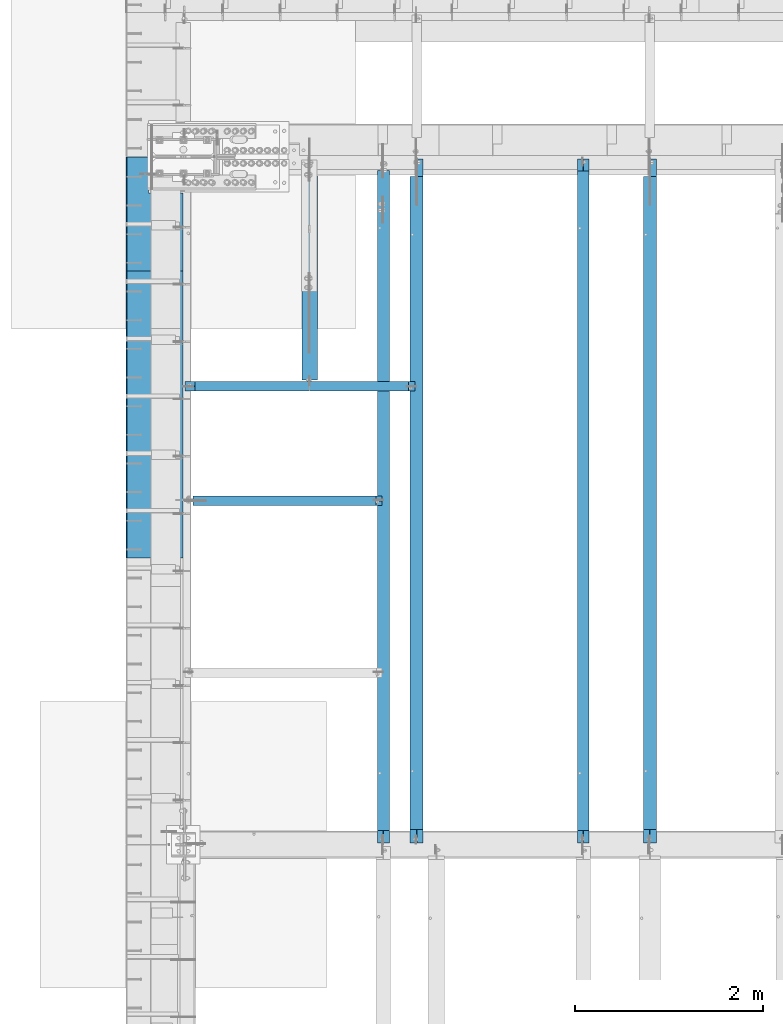
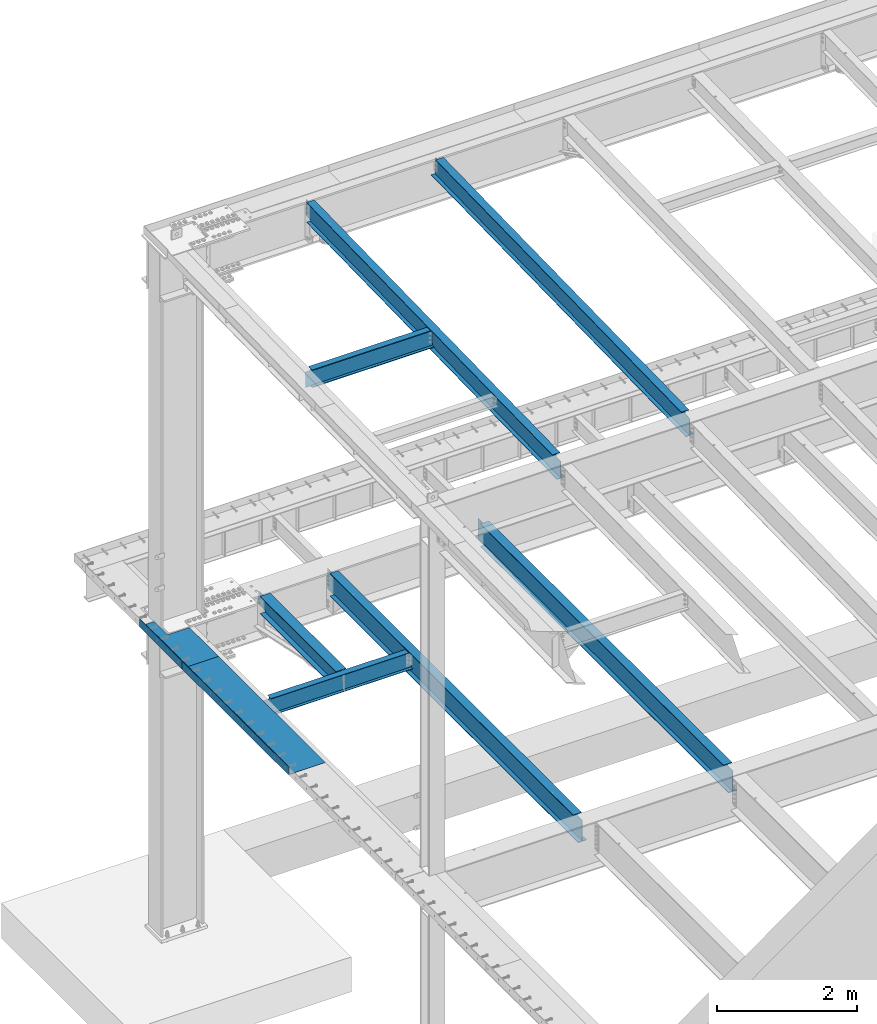
# One storey, part 1124 of 1763: 9 beams, 8 elements without a shape of their own.
"""IFC2X3 building model written with IfcOpenShell, lengths in millimetres."""

from ifc_helpers import new_model, si_unit, frame, origin_with_axes, place, context, subcontext, project, spatial, faceted_brep, material, type_object, element, aggregate, save


model = new_model("IFC2X3")

# Units and contexts
model_context = context("Model", 3, precision=1e-05, world=origin_with_axes())
body_context = subcontext(model_context, "Body", "Model", "MODEL_VIEW")
ifc_project = project(units=[si_unit("LENGTHUNIT", "METRE", prefix="MILLI"), si_unit("AREAUNIT", "SQUARE_METRE"), si_unit("VOLUMEUNIT", "CUBIC_METRE"), si_unit("MASSUNIT", "GRAM", prefix="KILO"), si_unit("TIMEUNIT", "SECOND"), si_unit("PLANEANGLEUNIT", "RADIAN"), si_unit("SOLIDANGLEUNIT", "STERADIAN"), si_unit("THERMODYNAMICTEMPERATUREUNIT", "DEGREE_CELSIUS"), si_unit("LUMINOUSINTENSITYUNIT", "LUMEN")], contexts=[model_context])

# Site, building, storey
site_placement = place(None, origin_with_axes())
site = spatial("IfcSite", under=ifc_project, at=site_placement, CompositionType="ELEMENT")
building_placement = place(site_placement, origin_with_axes())
building = spatial("IfcBuilding", under=site, at=building_placement, Name="Undefined", CompositionType="ELEMENT")
storey_placement = place(building_placement, origin_with_axes())
storey = spatial("IfcBuildingStorey", under=building, at=storey_placement, Name="Undefined", CompositionType="ELEMENT", Elevation=0.0)

# Assembly, beam
assembly_1_placement = place(storey_placement, origin_with_axes())
assembly_1 = element("IfcElementAssembly", 1, at=assembly_1_placement, inside=storey, Name="BEAM", AssemblyPlace="NOTDEFINED", PredefinedType="RIGID_FRAME")
ifc_material_1 = material(Name="STEEL/A992")
beam_type_1 = type_object("IfcBeamType", Name="W16X26", PredefinedType="NOTDEFINED")
beam_1_placement = place(assembly_1_placement, frame((-82413.9706070317, 44805.6, 4994.275), z_axis=(0.0, 0.0, 1.0), x_axis=(0.0, 1.0, 0.0)))
beam_1 = element("IfcBeam", 2, at=beam_1_placement, type_object=beam_type_1, material=ifc_material_1, Name="BEAM", ObjectType="W16X26", context=body_context, shape_type="Brep", body=[
    faceted_brep([(7104.06248869727, 3.17500000000291, -190.5), (7104.06248869734, 3.17487653380522, -200.025), (7104.06247902929, 69.8499999999985, -200.025), (7104.06247902929, 69.8499999999985, -190.5), (7294.5625, 3.17500000000291, -190.5), (7294.5625, 3.17490415680368, -200.025), (159.543749432261, 3.17500000000291, 190.5), (159.543749432261, 69.8499999999985, 190.5), (7104.0625, 69.8499999999985, 190.5), (7104.0625, 3.17500000000291, 190.5), (159.543749432261, -69.8499999999985, 200.025), (159.543749432261, 69.8499999999985, 200.025), (159.543749432261, 3.17500000000291, 180.715001487732), (159.543749432261, -3.17500000000291, 180.715001487732), (159.543749432261, -3.17500000000291, 190.5), (159.543749432261, -69.8499999999985, 190.5), (158.57701950967, 3.17500000000291, 175.854921969686), (158.57701950967, -3.17500000000291, 175.854921969686), (155.824005609196, 3.17500000000291, 171.734745501532), (155.824005609196, -3.17500000000291, 171.734745501532), (151.703829141043, 3.17500000000291, 168.981731601054), (151.703829141043, -3.17500000000291, 168.981731601054), (146.843749622996, 3.17500000000291, 168.015001678466), (146.843749622996, -3.17500000000291, 168.015001678466), (19.84375, 3.17500000000291, 168.015001678466), (19.84375, -3.17500000000291, 168.015001678466), (19.84375, 3.17500000000291, -190.5), (19.84375, 69.8499999999985, -190.5), (19.84375, 69.8499999999985, -200.025), (19.84375, -69.8499999999985, -200.025), (19.84375, -69.8499999999985, -190.5), (19.84375, -3.17500000000291, -190.5), (7294.5625, -69.8499999999985, -200.025), (7294.5625, -69.8499999999985, -190.5), (7294.5625, -3.17500000000291, -190.5), (7111.90242029122, -3.17500000000291, 156.541729922587), (7107.78224382307, -3.17500000000291, 159.294743823066), (7105.02922992258, -3.17500000000291, 163.414920291219), (7104.0625, -3.17500000000291, 168.274999809265), (7104.0625, -3.17500000000291, 190.5), (7294.5625, -3.17500000000291, 155.575), (7116.76249980927, -3.17500000000291, 155.575), (7104.0625, -69.8499999999985, 190.5), (7104.0625, -69.8499999999985, 200.025), (7104.0625, 69.8499999999985, 200.025), (7104.0625, 3.17500000000291, 168.274999809265), (7105.02922992258, 3.17500000000291, 163.414920291219), (7107.78224382307, 3.17500000000291, 159.294743823066), (7111.90242029122, 3.17500000000291, 156.541729922587), (7116.76249980927, 3.17500000000291, 155.575), (7294.5625, 3.17500000000291, 155.575), (7294.5625, 3.17500000000291, -184.976846570121)], [[[0, 1, 2, 3]], [[4, 5, 1, 0]], [[6, 7, 8, 9]], [[10, 11, 7, 6, 12, 13, 14, 15]], [[13, 12, 16, 17]], [[17, 16, 18, 19]], [[19, 18, 20, 21]], [[21, 20, 22, 23]], [[23, 22, 24, 25]], [[26, 27, 28, 29, 30, 31, 25, 24]], [[30, 29, 32, 33]], [[31, 30, 33, 34]], [[35, 36, 37, 38, 39, 14, 13, 17, 19, 21, 23, 25, 31, 34, 40, 41]], [[15, 14, 39, 42]], [[10, 15, 42, 43]], [[11, 10, 43, 44]], [[7, 11, 44, 8]], [[43, 42, 39, 38, 45, 9, 8, 44]], [[37, 46, 45, 38]], [[36, 47, 46, 37]], [[35, 48, 47, 36]], [[41, 49, 48, 35]], [[40, 50, 49, 41]], [[51, 4, 0, 26, 24, 22, 20, 18, 16, 12, 6, 9, 45, 46, 47, 48, 49, 50]], [[27, 26, 0, 3]], [[28, 27, 3, 2]], [[32, 29, 28, 2, 1, 5]], [[51, 50, 40, 34, 33, 32, 5, 4]]]),
])
aggregate(assembly_1, [beam_1])

assembly_2_placement = place(storey_placement, origin_with_axes())
assembly_2 = element("IfcElementAssembly", 3, at=assembly_2_placement, inside=storey, Name="BEAM", AssemblyPlace="NOTDEFINED", PredefinedType="RIGID_FRAME")
beam_2_placement = place(assembly_2_placement, frame((-84894.703940365, 44805.6, 4994.275), z_axis=(0.0, 0.0, 1.0), x_axis=(0.0, 1.0, 0.0)))
beam_2 = element("IfcBeam", 4, at=beam_2_placement, type_object=beam_type_1, material=ifc_material_1, Name="BEAM", ObjectType="W16X26", context=body_context, shape_type="Brep", body=[
    faceted_brep([(7104.06248869727, 3.17500000000291, -190.5), (7104.06248869734, 3.17487653380522, -200.025), (7104.06247902929, 69.8499999999985, -200.025), (7104.06247902929, 69.8499999999985, -190.5), (7294.5625, 3.17500000000291, -190.5), (7294.5625, 3.17490415680368, -200.025), (159.543749432261, 3.17500000000291, 190.5), (159.543749432261, 69.8499999999985, 190.5), (7104.0625, 69.8499999999985, 190.5), (7104.0625, 3.17500000000291, 190.5), (159.543749432261, -69.8499999999985, 200.025), (159.543749432261, 69.8499999999985, 200.025), (159.543749432261, 3.17500000000291, 180.715001487732), (159.543749432261, -3.17500000000291, 180.715001487732), (159.543749432261, -3.17500000000291, 190.5), (159.543749432261, -69.8499999999985, 190.5), (158.57701950967, 3.17500000000291, 175.854921969686), (158.57701950967, -3.17500000000291, 175.854921969686), (155.824005609196, 3.17500000000291, 171.734745501532), (155.824005609196, -3.17500000000291, 171.734745501532), (151.703829141043, 3.17500000000291, 168.981731601054), (151.703829141043, -3.17500000000291, 168.981731601054), (146.843749622996, 3.17500000000291, 168.015001678466), (146.843749622996, -3.17500000000291, 168.015001678466), (19.84375, 3.17500000000291, 168.015001678466), (19.84375, -3.17500000000291, 168.015001678466), (19.84375, 3.17500000000291, -190.5), (19.84375, 69.8499999999985, -190.5), (19.84375, 69.8499999999985, -200.025), (19.84375, -69.8499999999985, -200.025), (19.84375, -69.8499999999985, -190.5), (19.84375, -3.17500000000291, -190.5), (7294.5625, -69.8499999999985, -200.025), (7294.5625, -69.8499999999985, -190.5), (7294.5625, -3.17500000000291, -190.5), (7111.90242029122, -3.17500000000291, 156.541729922587), (7107.78224382307, -3.17500000000291, 159.294743823066), (7105.02922992258, -3.17500000000291, 163.414920291219), (7104.0625, -3.17500000000291, 168.274999809265), (7104.0625, -3.17500000000291, 190.5), (7294.5625, -3.17500000000291, 155.575), (7116.76249980927, -3.17500000000291, 155.575), (7104.0625, -69.8499999999985, 190.5), (7104.0625, -69.8499999999985, 200.025), (7104.0625, 69.8499999999985, 200.025), (7104.0625, 3.17500000000291, 168.274999809265), (7105.02922992258, 3.17500000000291, 163.414920291219), (7107.78224382307, 3.17500000000291, 159.294743823066), (7111.90242029122, 3.17500000000291, 156.541729922587), (7116.76249980927, 3.17500000000291, 155.575), (7294.5625, 3.17500000000291, 155.575), (7294.5625, 3.17500000000291, -184.976846570121)], [[[0, 1, 2, 3]], [[4, 5, 1, 0]], [[6, 7, 8, 9]], [[10, 11, 7, 6, 12, 13, 14, 15]], [[13, 12, 16, 17]], [[17, 16, 18, 19]], [[19, 18, 20, 21]], [[21, 20, 22, 23]], [[23, 22, 24, 25]], [[26, 27, 28, 29, 30, 31, 25, 24]], [[30, 29, 32, 33]], [[31, 30, 33, 34]], [[35, 36, 37, 38, 39, 14, 13, 17, 19, 21, 23, 25, 31, 34, 40, 41]], [[15, 14, 39, 42]], [[10, 15, 42, 43]], [[11, 10, 43, 44]], [[7, 11, 44, 8]], [[43, 42, 39, 38, 45, 9, 8, 44]], [[37, 46, 45, 38]], [[36, 47, 46, 37]], [[35, 48, 47, 36]], [[41, 49, 48, 35]], [[40, 50, 49, 41]], [[51, 4, 0, 26, 24, 22, 20, 18, 16, 12, 6, 9, 45, 46, 47, 48, 49, 50]], [[27, 26, 0, 3]], [[28, 27, 3, 2]], [[32, 29, 28, 2, 1, 5]], [[51, 50, 40, 34, 33, 32, 5, 4]]]),
])
aggregate(assembly_2, [beam_2])

assembly_3_placement = place(storey_placement, origin_with_axes())
assembly_3 = element("IfcElementAssembly", 5, at=assembly_3_placement, inside=storey, Name="BEAM", AssemblyPlace="NOTDEFINED", PredefinedType="RIGID_FRAME")
beam_type_2 = type_object("IfcBeamType", Name="W14X22", PredefinedType="NOTDEFINED")
beam_3_placement = place(assembly_3_placement, frame((-83122.7515594126, 44809.2121579121, 11421.5633921212), z_axis=(0.0, -0.0206852279954837, 0.999786037781472), x_axis=(0.0, 0.999786037781472, 0.0206852279954825)))
beam_3 = element("IfcBeam", 6, at=beam_3_placement, type_object=beam_type_2, material=ifc_material_1, Name="BEAM", ObjectType="W14X22", context=body_context, shape_type="Brep", body=[
    faceted_brep([(136.091146049795, -3.17500000000291, 123.565001678358), (136.091146049795, 3.17500000000291, 123.565001678358), (17.9976630864912, 3.17500000000291, 123.56500167838), (17.9976630864912, -3.17500000000291, 123.56500167838), (140.951225567893, -3.17500000000291, 124.531731600942), (140.951225567893, 3.17500000000291, 124.531731600942), (145.071402036083, -3.17500000000291, 127.284745501414), (145.071402036083, 3.17500000000291, 127.284745501414), (147.824415936586, -3.17500000000291, 131.404921969557), (147.824415936586, 3.17500000000291, 131.404921969557), (148.791145859177, -3.17500000000291, 136.265001487593), (148.791145859177, 3.17500000000291, 136.265001487593), (148.79114585917, -63.5, 174.624999999827), (148.79114585917, 63.5, 174.624999999827), (148.791145859177, 63.5, 166.687499999833), (148.791145859177, 3.17500000000291, 166.687499999833), (148.791145859177, -3.17500000000291, 166.687499999833), (148.791145859177, -63.5, 166.687499999833), (11.9924390219312, -3.17500000000291, -166.687499999878), (11.9924390219312, -63.5, -166.687499999878), (7289.06195724197, -63.5, -166.687500001812), (7289.06195724197, -3.17500000000291, -166.687500001812), (11.8282148869548, -63.5, -174.624999999871), (7288.89773310699, -63.5, -174.625000001806), (11.8282148869548, 63.5, -174.624999999871), (7288.89773310699, 63.5, -174.625000001806), (11.9924390219312, 63.5, -166.687499999878), (7289.06195724197, 63.5, -166.687500001812), (11.9924390219312, 3.17500000000291, -166.687499999878), (7289.06195724197, 3.17500000000291, -166.687500001812), (7294.93580191941, 3.17500000000291, 117.21499785159), (7294.93580191941, -3.17500000000291, 117.21499785159), (7178.21066392501, 3.17500000000291, 117.214997851612), (7178.21066392501, -3.17500000000291, 117.214997851612), (7173.35058440694, 3.17500000000291, 118.181727774199), (7173.35058440694, -3.17500000000291, 118.181727774199), (7169.23040793875, 3.17500000000291, 120.934741674671), (7169.23040793875, -3.17500000000291, 120.934741674671), (7166.47739403824, 3.17500000000291, 125.054918142816), (7166.47739403824, -3.17500000000291, 125.054918142816), (7165.51066411565, 3.17500000000291, 129.91499766085), (7165.51066411565, -3.17500000000291, 129.91499766085), (7165.51066411565, -63.5, 174.624999997965), (7165.51066411565, -63.5, 166.68749999797), (7165.51066411565, -3.17500000000291, 166.68749999797), (7165.51066411565, 3.17500000000291, 166.68749999797), (7165.51066411565, 63.5, 166.68749999797), (7165.51066411565, 63.5, 174.624999997965)], [[[0, 1, 2, 3]], [[4, 5, 1, 0]], [[6, 7, 5, 4]], [[8, 9, 7, 6]], [[10, 11, 9, 8]], [[12, 13, 14, 15, 11, 10, 16, 17]], [[18, 19, 20, 21]], [[19, 22, 23, 20]], [[22, 24, 25, 23]], [[24, 26, 27, 25]], [[26, 28, 29, 27]], [[21, 20, 23, 25, 27, 29, 30, 31]], [[31, 30, 32, 33]], [[33, 32, 34, 35]], [[35, 34, 36, 37]], [[37, 36, 38, 39]], [[39, 38, 40, 41]], [[42, 43, 44, 41, 40, 45, 46, 47]], [[43, 42, 12, 17]], [[44, 43, 17, 16]], [[8, 6, 4, 0, 3, 18, 21, 31, 33, 35, 37, 39, 41, 44, 16, 10]], [[28, 26, 24, 22, 19, 18, 3, 2]], [[45, 40, 38, 36, 34, 32, 30, 29, 28, 2, 1, 5, 7, 9, 11, 15]], [[46, 45, 15, 14]], [[47, 46, 14, 13]], [[42, 47, 13, 12]]]),
])
aggregate(assembly_3, [beam_3])

assembly_4_placement = place(storey_placement, origin_with_axes())
assembly_4 = element("IfcElementAssembly", 7, at=assembly_4_placement, inside=storey, Name="BEAM", AssemblyPlace="NOTDEFINED", PredefinedType="RIGID_FRAME")
beam_4_placement = place(assembly_4_placement, frame((-85249.0944165555, 44809.2121579121, 11421.5633921212), z_axis=(0.0, -0.0206852279954837, 0.999786037781472), x_axis=(0.0, 0.999786037781472, 0.0206852279954825)))
beam_4 = element("IfcBeam", 8, at=beam_4_placement, type_object=beam_type_2, material=ifc_material_1, Name="BEAM", ObjectType="W14X22", context=body_context, shape_type="Brep", body=[
    faceted_brep([(136.091146049795, -3.17500000000291, 123.565001678358), (136.091146049795, 3.17500000000291, 123.565001678358), (17.9976630864912, 3.17500000000291, 123.56500167838), (17.9976630864912, -3.17500000000291, 123.56500167838), (140.951225567893, -3.17500000000291, 124.531731600942), (140.951225567893, 3.17500000000291, 124.531731600942), (145.071402036083, -3.17500000000291, 127.284745501414), (145.071402036083, 3.17500000000291, 127.284745501414), (147.824415936586, -3.17500000000291, 131.404921969557), (147.824415936586, 3.17500000000291, 131.404921969557), (148.791145859177, -3.17500000000291, 136.265001487593), (148.791145859177, 3.17500000000291, 136.265001487593), (148.79114585917, -63.5, 174.624999999827), (148.79114585917, 63.5, 174.624999999827), (148.791145859177, 63.5, 166.687499999833), (148.791145859177, 3.17500000000291, 166.687499999833), (148.791145859177, -3.17500000000291, 166.687499999833), (148.791145859177, -63.5, 166.687499999833), (11.9924390219312, -3.17500000000291, -166.687499999878), (11.9924390219312, -63.5, -166.687499999878), (7162.77359555585, -63.5, -166.687500001777), (7162.77359555585, -3.17500000000291, -166.687500001777), (11.8282148869548, -63.5, -174.624999999871), (7162.77359555585, -63.5, -174.625000001772), (11.8282148869548, 63.5, -174.624999999871), (7162.77359555585, 63.5, -174.625000001772), (11.9924390219312, 63.5, -166.687499999878), (7162.77359555585, 63.5, -166.687500001777), (11.9924390219312, 3.17500000000291, -166.687499999878), (7162.77359555585, 3.17500000000291, -166.687500001777), (7162.77359555586, 3.17500000000291, -155.574999838074), (7162.77359555586, -3.17500000000291, -155.574999838074), (7163.74032547845, 3.17500000000291, -150.714920320039), (7163.74032547845, -3.17500000000291, -150.714920320039), (7166.49333937895, 3.17500000000291, -146.594743851894), (7166.49333937895, -3.17500000000291, -146.594743851894), (7170.61351584714, 3.17500000000291, -143.841729951426), (7170.61351584714, -3.17500000000291, -143.841729951426), (7175.47359536523, 3.17500000000291, -142.87500002884), (7175.47359536523, -3.17500000000291, -142.87500002884), (7289.55462988591, -3.17500000000291, -142.875000028898), (7289.55462988591, 3.17500000000291, -142.875000028898), (7295.20394014482, 3.17500000000291, 130.17500073325), (7295.20394014482, -3.17500000000291, 130.17500073325), (7181.82359536537, 3.17500000000291, 130.175000733272), (7181.82359536537, -3.17500000000291, 130.175000733272), (7176.96351584728, 3.17500000000291, 131.14173065586), (7176.96351584728, -3.17500000000291, 131.14173065586), (7172.8433393791, 3.17500000000291, 133.894744556334), (7172.8433393791, -3.17500000000291, 133.894744556334), (7170.0903254786, 3.17500000000291, 138.014921024478), (7170.0903254786, -3.17500000000291, 138.014921024478), (7169.123595556, 3.17500000000291, 142.875000542512), (7169.123595556, -3.17500000000291, 142.875000542512), (7169.123595556, -63.5, 174.624999997965), (7169.123595556, -63.5, 166.68749999797), (7169.123595556, -3.17500000000291, 166.68749999797), (7169.123595556, 3.17500000000291, 166.68749999797), (7169.123595556, 63.5, 166.68749999797), (7169.123595556, 63.5, 174.624999997965)], [[[0, 1, 2, 3]], [[4, 5, 1, 0]], [[6, 7, 5, 4]], [[8, 9, 7, 6]], [[10, 11, 9, 8]], [[12, 13, 14, 15, 11, 10, 16, 17]], [[18, 19, 20, 21]], [[19, 22, 23, 20]], [[22, 24, 25, 23]], [[24, 26, 27, 25]], [[26, 28, 29, 27]], [[21, 20, 23, 25, 27, 29, 30, 31]], [[31, 30, 32, 33]], [[33, 32, 34, 35]], [[35, 34, 36, 37]], [[37, 36, 38, 39]], [[40, 39, 38, 41]], [[42, 43, 40, 41]], [[43, 42, 44, 45]], [[45, 44, 46, 47]], [[47, 46, 48, 49]], [[49, 48, 50, 51]], [[51, 50, 52, 53]], [[54, 55, 56, 53, 52, 57, 58, 59]], [[12, 17, 55, 54]], [[17, 16, 56, 55]], [[43, 45, 47, 49, 51, 53, 56, 16, 10, 8, 6, 4, 0, 3, 18, 21, 31, 33, 35, 37, 39, 40]], [[28, 26, 24, 22, 19, 18, 3, 2]], [[36, 34, 32, 30, 29, 28, 2, 1, 5, 7, 9, 11, 15, 57, 52, 50, 48, 46, 44, 42, 41, 38]], [[15, 14, 58, 57]], [[14, 13, 59, 58]], [[13, 12, 54, 59]]]),
])
aggregate(assembly_4, [beam_4])

# Assembly, beams
assembly_5_placement = place(storey_placement, origin_with_axes())
assembly_5 = element("IfcElementAssembly", 9, at=assembly_5_placement, inside=storey, Name="BEAM", AssemblyPlace="NOTDEFINED", PredefinedType="RIGID_FRAME")
ifc_material_2 = material(Name="STEEL/A36")
beam_type_3 = type_object("IfcBeamType", PredefinedType="NOTDEFINED")
beam_5_placement = place(assembly_5_placement, frame((-87381.7872736983, 51511.2005, 5199.0625), z_axis=(0.0, -1.0, 0.0), x_axis=(-1.0, 0.0, 0.0)))
beam_5 = element("IfcBeam", 10, at=beam_5_placement, type_object=beam_type_3, material=ifc_material_2, Name="BENT_PLATE", context=body_context, shape_type="Brep", body=[
    faceted_brep([(363.537500000006, -4.76249999999982, -225.423999999999), (363.537500000006, 4.76249999999982, -225.423999999999), (363.537500000006, 4.76249999999982, -606.425000000003), (363.537500000006, -4.76249999999982, -606.425000000003), (0.0, -4.76249999999982, -225.423999999999), (0.0, 4.76249999999982, -225.423999999999), (603.25, 4.76249999999982, 606.425000000003), (0.0, 4.76249999999982, 606.425000000003), (0.0, -4.76249999999982, 606.425000000003), (593.725000000006, -4.76249999999982, 606.425000000003), (593.725000000006, -134.937496948242, 606.425000000003), (603.25, -134.937496948242, 606.425000000003), (603.25, 4.76249999999982, -606.425000000003), (603.25, -134.937496948242, -606.425000000003), (593.725000000006, -134.937496948242, -606.425000000003), (593.725000000006, -4.76249999999982, -606.425000000003)], [[[0, 1, 2, 3]], [[4, 5, 1, 0]], [[6, 7, 8, 9, 10, 11]], [[12, 6, 11, 13]], [[10, 14, 13, 11]], [[9, 15, 14, 10]], [[12, 13, 14, 15, 3, 2]], [[7, 6, 12, 2, 1, 5]], [[8, 7, 5, 4]], [[15, 9, 8, 4, 0, 3]]]),
])
beam_6_placement = place(assembly_5_placement, frame((-87381.7872736983, 49380.7755, 5199.0625), z_axis=(0.0, -1.0, 0.0), x_axis=(-1.0, 0.0, 0.0)))
beam_6 = element("IfcBeam", 11, at=beam_6_placement, type_object=beam_type_3, material=ifc_material_2, Name="BENT_PLATE", context=body_context, shape_type="Brep", body=[
    faceted_brep([(0.0, -4.76249999999982, -1524.0), (0.0, -4.76249999999982, 1524.0), (0.0, 4.76249999999982, 1524.0), (0.0, 4.76249999999982, -1524.0), (603.25, 4.76249999999982, 1524.0), (603.25, 4.76249999999982, -1524.0), (593.725000000006, -4.76249999999982, -1524.0), (593.725000000006, -4.76249999999982, 1524.0), (603.25, -134.937496948242, 1524.0), (603.25, -134.937496948242, -1524.0), (593.725000000006, -134.937496948242, 1524.0), (593.725000000006, -134.937496948242, -1524.0)], [[[0, 1, 2, 3]], [[3, 2, 4, 5]], [[1, 0, 6, 7]], [[5, 4, 8, 9]], [[4, 2, 1, 7, 10, 8]], [[7, 6, 11, 10]], [[6, 0, 3, 5, 9, 11]], [[10, 11, 9, 8]]]),
])
aggregate(assembly_5, [beam_5, beam_6])

# Assembly, beam
assembly_6_placement = place(storey_placement, origin_with_axes())
assembly_6 = element("IfcElementAssembly", 12, at=assembly_6_placement, inside=storey, Name="BEAM", AssemblyPlace="NOTDEFINED", PredefinedType="RIGID_FRAME")
beam_type_4 = type_object("IfcBeamType", Name="W12X26", PredefinedType="NOTDEFINED")
beam_7_placement = place(assembly_6_placement, frame((-86029.2372736984, 49682.4, 5038.725), z_axis=(0.0, 0.0, 1.0), x_axis=(0.0, 1.0, 0.0)))
beam_7 = element("IfcBeam", 13, at=beam_7_placement, type_object=beam_type_4, material=ifc_material_1, Name="BEAM", ObjectType="W12X26", context=body_context, shape_type="Brep", body=[
    faceted_brep([(15.0812499999956, -3.17500000000291, -111.125), (15.0812499999956, 3.17500000000291, -111.125), (53.1812501907261, 3.17500000000291, -111.125), (53.1812501907261, -3.17500000000291, -111.125), (58.0413297087725, 3.17500000000291, -112.091729922588), (58.0413297087725, -3.17500000000291, -112.091729922588), (62.1615061769262, 3.17500000000291, -114.844743823066), (62.1615061769262, -3.17500000000291, -114.844743823066), (64.9145200774001, 3.17500000000291, -118.96492029122), (64.9145200774001, -3.17500000000291, -118.96492029122), (65.8812499999913, -3.17500000000291, -123.824999809265), (65.8812499999913, 3.17500000000291, -123.824999809265), (65.8812499999913, 3.17500000000291, -146.05), (65.8812499999913, 82.5500000000029, -146.05), (65.8812499999913, 82.5500000000029, -155.575), (65.8812499999913, -82.5500000000029, -155.575), (65.8812499999913, -82.5500000000029, -146.05), (65.8812499999913, -3.17500000000291, -146.05), (65.8812499999913, 3.17500000000291, 146.05), (65.8812499999913, 82.5500000000029, 146.05), (2233.6125, 82.5500000000029, 146.05), (2233.6125, 3.17500000000291, 146.05), (53.1812501907261, -3.17500000000291, 117.475), (53.1812501907261, 3.17500000000291, 117.475), (15.0812499999956, 3.17500000000291, 117.475), (15.0812499999956, -3.17500000000291, 117.475), (58.0413297087725, -3.17500000000291, 118.441729922588), (58.0413297087725, 3.17500000000291, 118.441729922588), (62.1615061769262, -3.17500000000291, 121.194743823066), (62.1615061769262, 3.17500000000291, 121.194743823066), (64.9145200774001, -3.17500000000291, 125.31492029122), (64.9145200774001, 3.17500000000291, 125.31492029122), (65.8812499999913, -3.17500000000291, 130.174999809266), (65.8812499999913, 3.17500000000291, 130.174999809266), (65.8812499999913, 82.5500000000029, 155.575), (65.8812499999913, -82.5500000000029, 155.575), (2233.6125, -82.5500000000029, 155.575), (2233.6125, 82.5500000000029, 155.575), (65.8812499999913, -82.5500000000029, 146.05), (2233.6125, -82.5500000000029, 146.05), (65.8812499999913, -3.17500000000291, 146.05), (2233.6125, -3.17500000000291, 146.05), (2233.6125, -3.17500000000291, 123.824999809265), (2233.6125, 3.17500000000291, 123.824999809265), (2234.57922992259, -3.17500000000291, 118.96492029122), (2234.57922992259, 3.17500000000291, 118.96492029122), (2237.33224382307, -3.17500000000291, 114.844743823066), (2237.33224382307, 3.17500000000291, 114.844743823066), (2241.45242029122, -3.17500000000291, 112.091729922588), (2241.45242029122, 3.17500000000291, 112.091729922588), (2246.31249980927, -3.17500000000291, 111.125), (2246.31249980927, 3.17500000000291, 111.125), (2417.7625, -3.17500000000291, 111.125), (2417.7625, 3.17500000000291, 111.125), (2417.7625, -3.17500000000291, -111.125), (2417.7625, 3.17500000000291, -111.125), (2246.31249980927, -3.17500000000291, -111.125), (2246.31249980927, 3.17500000000291, -111.125), (2241.45242029122, -3.17500000000291, -112.091729922588), (2241.45242029122, 3.17500000000291, -112.091729922588), (2237.33224382307, -3.17500000000291, -114.844743823066), (2237.33224382307, 3.17500000000291, -114.844743823066), (2234.57922992259, -3.17500000000291, -118.96492029122), (2234.57922992259, 3.17500000000291, -118.96492029122), (2233.6125, -3.17500000000291, -123.824999809265), (2233.6125, 3.17500000000291, -123.824999809265), (2233.6125, -3.17500000000291, -146.05), (2233.6125, -82.5500000000029, -146.05), (2233.6125, -82.5500000000029, -155.575), (2233.6125, 82.5500000000029, -155.575), (2233.6125, 82.5500000000029, -146.05), (2233.6125, 3.17500000000291, -146.05)], [[[0, 1, 2, 3]], [[3, 2, 4, 5]], [[5, 4, 6, 7]], [[7, 6, 8, 9]], [[10, 11, 12, 13, 14, 15, 16, 17]], [[9, 8, 11, 10]], [[18, 19, 20, 21]], [[22, 23, 24, 25]], [[26, 27, 23, 22]], [[28, 29, 27, 26]], [[30, 31, 29, 28]], [[32, 33, 31, 30]], [[34, 35, 36, 37]], [[35, 38, 39, 36]], [[38, 40, 41, 39]], [[35, 34, 19, 18, 33, 32, 40, 38]], [[19, 34, 37, 20]], [[36, 39, 41, 42, 43, 21, 20, 37]], [[44, 45, 43, 42]], [[46, 47, 45, 44]], [[48, 49, 47, 46]], [[50, 51, 49, 48]], [[52, 53, 51, 50]], [[53, 52, 54, 55]], [[54, 56, 57, 55]], [[58, 59, 57, 56]], [[60, 61, 59, 58]], [[62, 63, 61, 60]], [[64, 65, 63, 62]], [[66, 67, 68, 69, 70, 71, 65, 64]], [[17, 16, 67, 66]], [[16, 15, 68, 67]], [[15, 14, 69, 68]], [[14, 13, 70, 69]], [[13, 12, 71, 70]], [[59, 61, 63, 65, 71, 12, 11, 8, 6, 4, 2, 1, 24, 23, 27, 29, 31, 33, 18, 21, 43, 45, 47, 49, 51, 53, 55, 57]], [[25, 24, 1, 0]], [[52, 50, 48, 46, 44, 42, 41, 40, 32, 30, 28, 26, 22, 25, 0, 3, 5, 7, 9, 10, 17, 66, 64, 62, 60, 58, 56, 54]]]),
])
aggregate(assembly_6, [beam_7])

assembly_7_placement = place(storey_placement, origin_with_axes())
assembly_7 = element("IfcElementAssembly", 14, at=assembly_7_placement, inside=storey, Name="BEAM", AssemblyPlace="NOTDEFINED", PredefinedType="RIGID_FRAME")
beam_type_5 = type_object("IfcBeamType", Name="W12X22", PredefinedType="NOTDEFINED")
beam_8_placement = place(assembly_7_placement, frame((-87375.4372736983, 48463.2000000932, 11516.2505103669), z_axis=(0.0, 0.0, 1.0), x_axis=(1.0, 0.0, 0.0)))
beam_8 = element("IfcBeam", 15, at=beam_8_placement, type_object=beam_type_5, material=ifc_material_1, Name="BEAM", ObjectType="W12X22", context=body_context, shape_type="Brep", body=[
    faceted_brep([(17.4624499999918, -3.17500000000291, -144.4625), (17.4624499999918, -3.17471662999742, -155.575000000001), (100.012506951127, -3.17464117944473, -155.575000000001), (100.012506951782, -3.17500000000291, -144.4625), (100.012550480649, -50.8000000000029, -144.4625), (100.012550480649, -50.8000000000029, -155.575000000001), (2110.46785714285, 50.8000000000029, -144.4625), (2110.46785714285, 50.8000000000029, -155.575000000001), (111.125450000007, 50.8000000000029, -155.575000000001), (111.125450000007, 50.8000000000029, -144.4625), (100.012498093798, 3.17566108028404, -144.4625), (111.125450000007, 3.17575007543201, -144.4625), (111.125450000007, 3.17575007543201, -155.575000000001), (100.012498101321, 3.17575007543201, -155.575000000001), (17.4624499999918, 3.17575007543201, -155.575000000001), (17.4624499999918, 3.17500000000291, -144.4625), (2110.46785714285, 3.17500000000291, -144.4625), (2046.96785714285, -50.8000000000029, 155.575000000001), (2046.96785714285, -50.8000000000029, 144.4625), (2046.96785714285, -3.17500000000291, 144.4625), (2046.96785714285, -3.17500000000291, 129.915001486936), (2046.96785714285, 3.17500000000291, 129.915001486936), (2046.96785714285, 3.17500000000291, 144.4625), (2046.96785714285, 50.8000000000029, 144.4625), (2046.96785714285, 50.8000000000029, 155.575000000001), (2047.93458706544, -3.17500000000291, 125.054921968889), (2047.93458706544, 3.17500000000291, 125.054921968889), (2050.68760096592, -3.17500000000291, 120.934745500736), (2050.68760096592, 3.17500000000291, 120.934745500736), (2054.80777743408, -3.17500000000291, 118.181731600258), (2054.80777743408, 3.17500000000291, 118.181731600258), (2059.66785695212, -3.17500000000291, 117.21500167767), (2059.66785695212, 3.17500000000291, 117.21500167767), (2110.46785714285, -3.17500000000291, 117.21500167767), (2110.46785714285, 3.17500000000291, 117.21500167767), (2110.46785714285, -3.17500000000291, -144.4625), (2110.46785714285, -50.8000000000029, -144.4625), (2110.46785714285, -50.8000000000029, -155.575000000001), (17.4624499999918, -3.17500000000291, -137.353486546182), (17.4624499999918, -3.17500000000291, 117.474999997332), (17.4624499999918, 3.17500000000291, 117.474999997332), (17.4624499999918, 3.17500000000291, -137.353076315647), (87.3124501907005, -3.17500000000291, 117.474999997332), (87.3124501907005, 3.17498832568526, 117.474999997332), (92.1725297087396, -3.17500000000291, 118.441729919919), (92.1725297087396, 3.17498706730839, 118.441729919919), (96.2927061769005, -3.17500000000291, 121.194743820397), (96.2927061769005, 3.1749834837392, 121.194743820397), (99.0457200773817, -3.17500000000291, 125.314920288551), (99.0457200773817, 3.17497812055808, 125.314920288551), (100.012449999966, -3.17500000000291, 130.174999806597), (100.012449999966, 3.17497179425118, 130.174999806597), (100.012449999966, 3.17500000000291, 144.4625), (100.012449999966, 50.8000000000029, 144.4625), (100.012449999966, 50.8000000000029, 155.575000000001), (100.012449999966, -50.8000000000029, 155.575000000001), (100.012449999966, -50.8000000000029, 144.4625), (100.012449999966, -3.17500000000291, 144.4625)], [[[0, 1, 2, 3]], [[4, 3, 2, 5]], [[6, 7, 8, 9]], [[10, 11, 12, 13, 14, 15]], [[9, 8, 12, 11]], [[16, 6, 9, 11]], [[17, 18, 19, 20, 21, 22, 23, 24]], [[25, 26, 21, 20]], [[27, 28, 26, 25]], [[29, 30, 28, 27]], [[31, 32, 30, 29]], [[33, 34, 32, 31]], [[35, 36, 37, 7, 6, 16, 34, 33]], [[37, 36, 4, 5]], [[1, 14, 13, 12, 8, 7, 37, 5, 2]], [[38, 39, 40, 41, 15, 14, 1, 0]], [[42, 43, 40, 39]], [[44, 45, 43, 42]], [[46, 47, 45, 44]], [[48, 49, 47, 46]], [[50, 51, 49, 48]], [[22, 21, 26, 28, 30, 32, 34, 16, 11, 10, 15, 41, 40, 43, 45, 47, 49, 51, 52]], [[23, 22, 52, 53]], [[24, 23, 53, 54]], [[17, 24, 54, 55]], [[18, 17, 55, 56]], [[19, 18, 56, 57]], [[55, 54, 53, 52, 51, 50, 57, 56]], [[48, 46, 44, 42, 39, 38, 0, 3, 35, 33, 31, 29, 27, 25, 20, 19, 57, 50]], [[36, 35, 3, 4]]]),
])
aggregate(assembly_7, [beam_8])

assembly_8_placement = place(storey_placement, origin_with_axes())
assembly_8 = element("IfcElementAssembly", 16, at=assembly_8_placement, inside=storey, Name="BEAM", AssemblyPlace="NOTDEFINED", PredefinedType="RIGID_FRAME")
beam_type_6 = type_object("IfcBeamType", Name="W12X14", PredefinedType="NOTDEFINED")
beam_9_placement = place(assembly_8_placement, frame((-87375.4372736983, 49682.4, 5043.4875), z_axis=(0.0, 0.0, 1.0), x_axis=(1.0, 0.0, 0.0)))
beam_9 = element("IfcBeam", 17, at=beam_9_placement, type_object=beam_type_6, material=ifc_material_1, Name="BEAM", ObjectType="W12X14", context=body_context, shape_type="Brep", body=[
    faceted_brep([(2395.00833333333, -50.8000000000029, 150.8125), (2395.00833333333, -50.8000000000029, 144.4625), (2395.00833333333, -2.38124999999854, 144.4625), (2395.00833333333, -2.38124999999854, 137.852501487731), (2395.00833333333, 2.38124999999854, 137.852501487731), (2395.00833333333, 2.38124999999854, 144.4625), (2395.00833333333, 50.8000000000029, 144.4625), (2395.00833333333, 50.8000000000029, 150.8125), (2395.97506325592, -2.38124999999854, 132.992421969686), (2395.97506325592, 2.38124999999854, 132.992421969686), (2398.7280771564, -2.38124999999854, 128.872245501532), (2398.7280771564, 2.38124999999854, 128.872245501532), (2402.84825362456, -2.38124999999854, 126.119231601054), (2402.84825362456, 2.38124999999854, 126.119231601054), (2407.7083331426, -2.38124999999854, 125.152501678466), (2407.7083331426, 2.38124999999854, 125.152501678466), (2464.85833333334, -2.38124999999854, 125.152501678466), (2464.85833333334, 2.38124999999854, 125.152501678466), (124.618750000001, -50.8000000000029, 150.8125), (124.618750000001, 50.8000000000029, 150.8125), (124.618750000001, 50.8000000000029, 144.4625), (124.618750000001, 2.38124999999854, 144.4625), (124.618750000001, 2.38124999999854, 131.502501487732), (124.618750000001, -2.38124999999854, 131.502501487732), (124.618750000001, -2.38124999999854, 144.4625), (124.618750000001, -50.8000000000029, 144.4625), (123.65202007741, 2.38124999999854, 126.642421969686), (123.65202007741, -2.38124999999854, 126.642421969686), (120.899006176936, 2.38124999999854, 122.522245501533), (120.899006176936, -2.38124999999854, 122.522245501533), (116.778829708783, 2.38124999999854, 119.769231601054), (116.778829708783, -2.38124999999854, 119.769231601054), (111.918750190736, 2.38124999999854, 118.802501678467), (111.918750190736, -2.38124999999854, 118.802501678467), (16.6687499999971, 2.38124999999854, 118.802501678467), (16.6687499999971, -2.38124999999854, 118.802501678467), (16.6687499999971, 2.38124999999854, -144.4625), (16.6687499999898, 50.7999999999993, -144.4625), (16.6687499999971, 50.8000000000029, -150.8125), (16.6687499999971, -50.8000000000029, -150.8125), (16.6687499999898, -50.7999999999993, -144.4625), (16.6687499999971, -2.38124999999854, -144.4625), (2464.85833333334, 2.38124999999854, -144.4625), (2464.85833333334, 50.8000000000029, -144.4625), (2464.85833333334, 50.8000000000029, -150.8125), (2464.85833333334, -50.8000000000029, -150.8125), (2464.85833333334, -50.8000000000029, -144.4625), (2464.85833333334, -2.38124999999854, -144.4625)], [[[0, 1, 2, 3, 4, 5, 6, 7]], [[8, 9, 4, 3]], [[10, 11, 9, 8]], [[12, 13, 11, 10]], [[14, 15, 13, 12]], [[16, 17, 15, 14]], [[18, 19, 20, 21, 22, 23, 24, 25]], [[23, 22, 26, 27]], [[27, 26, 28, 29]], [[29, 28, 30, 31]], [[31, 30, 32, 33]], [[33, 32, 34, 35]], [[36, 37, 38, 39, 40, 41, 35, 34]], [[37, 36, 42, 43]], [[38, 37, 43, 44]], [[39, 38, 44, 45]], [[40, 39, 45, 46]], [[41, 40, 46, 47]], [[12, 10, 8, 3, 2, 24, 23, 27, 29, 31, 33, 35, 41, 47, 16, 14]], [[25, 24, 2, 1]], [[18, 25, 1, 0]], [[19, 18, 0, 7]], [[20, 19, 7, 6]], [[21, 20, 6, 5]], [[42, 36, 34, 32, 30, 28, 26, 22, 21, 5, 4, 9, 11, 13, 15, 17]], [[47, 46, 45, 44, 43, 42, 17, 16]]]),
])
aggregate(assembly_8, [beam_9])

save(model, "model.ifc")
